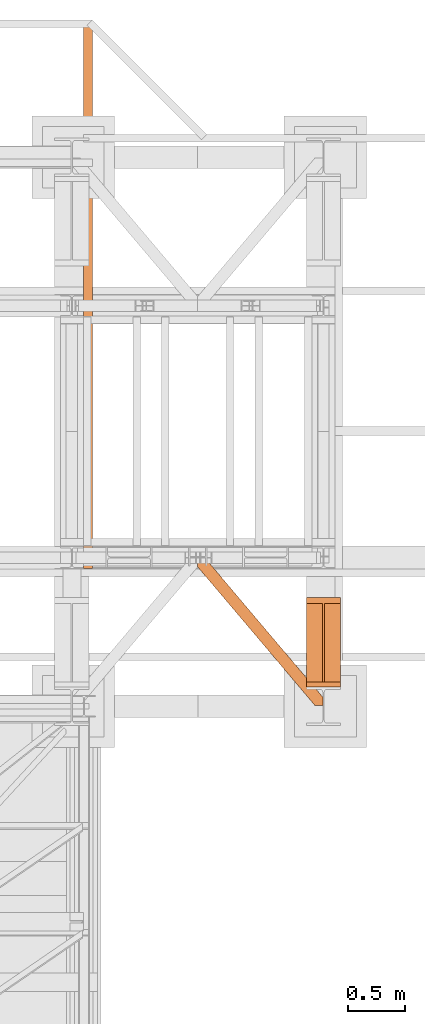
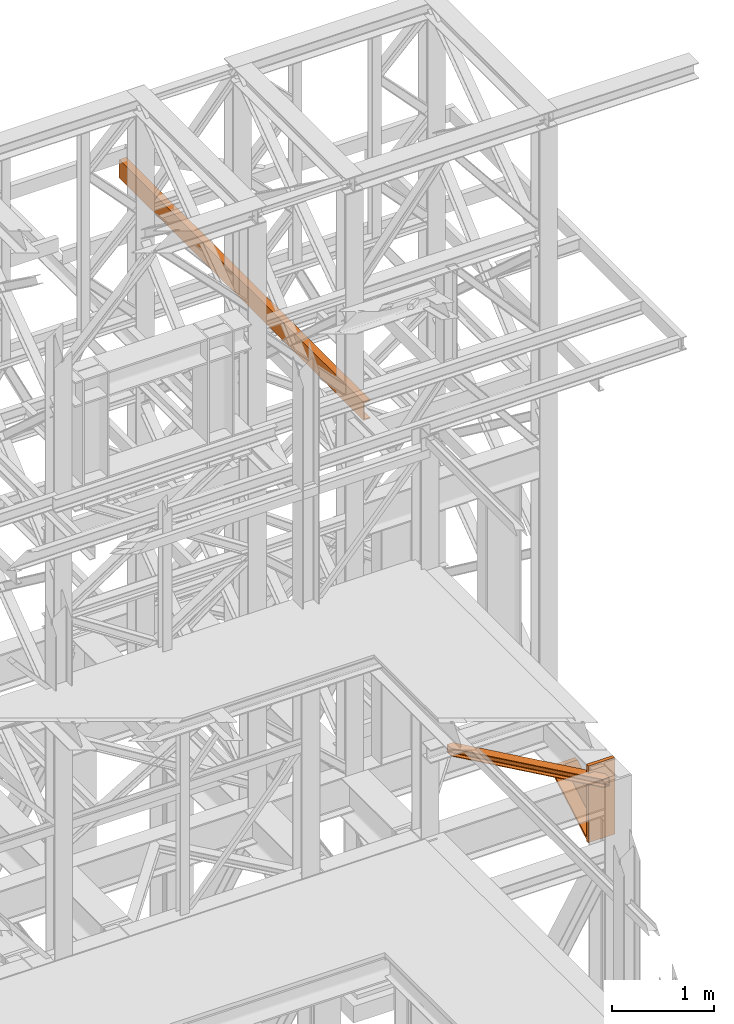
# One storey, part 175 of 208: 3 proxies.
"""IFC2X3 building model written with IfcOpenShell, lengths in millimetres."""

from ifc_helpers import new_model, entity, si_unit, converted_unit, frame, origin, origin_with_axes, place, context, subcontext, project, spatial, faceted_brep, element, save


model = new_model("IFC2X3")

# Units and contexts
model_context = context("Model", 3, precision=1e-05, world=origin())
plan_context = context("Plan", 3, precision=1e-05, world=origin())
body_context = subcontext(model_context, "Body", "Model", "MODEL_VIEW")
ifc_project = project(units=[si_unit("LENGTHUNIT", "METRE", prefix="MILLI"), converted_unit("PLANEANGLEUNIT", "DEGREE", entity("IfcPlaneAngleMeasure", 0.0174532925199433), si_unit("PLANEANGLEUNIT", "RADIAN"), dimensions=[0, 0, 0, 0, 0, 0, 0]), si_unit("AREAUNIT", "SQUARE_METRE"), si_unit("VOLUMEUNIT", "CUBIC_METRE")], contexts=[model_context, plan_context])

# Building, storey
building_placement = place(None, origin())
building = spatial("IfcBuilding", under=ifc_project, at=building_placement, CompositionType="COMPLEX")
storey_placement = place(building_placement, origin_with_axes())
storey = spatial("IfcBuildingStorey", under=building, at=storey_placement, Name="Geschoss", CompositionType="ELEMENT")

# Proxies
proxy_1_placement = place(storey_placement, frame((8643.254974489131, -17092.57439173937, 4367.230005364415), z_axis=(0.0, 0.0, 1.0), x_axis=(1.0, 0.0, 0.0)))
element("IfcBuildingElementProxy", 1, at=proxy_1_placement, inside=storey, context=body_context, shape_type="Brep", body=[
    faceted_brep([(0.01000000000021828, 40.0099999999984, 18.61000000000058), (300.0100000000002, 40.0099999999984, 18.61000000000058), (300.0100000000002, 779.8719999999976, 445.7700000000004), (0.01000000000021828, 779.8719999999976, 445.7700000000004), (0.01000000000021828, 779.8719999999976, 445.7700000000004), (300.0100000000002, 779.8719999999976, 445.7700000000004), (300.0100000000002, 729.8159999999989, 445.7710000000006), (157.5100000000002, 729.8159999999989, 445.7710000000006), (157.5100000000002, 40.0099999999984, 445.7700000000004), (142.5100000000002, 40.0099999999984, 445.7700000000004), (142.5100000000002, 729.8159999999989, 445.7710000000006), (0.01000000000021828, 729.8159999999971, 445.7710000000006), (0.01000000000021828, 729.8159999999971, 445.7710000000006), (142.5100000000002, 729.8159999999989, 445.7710000000006), (142.5100000000002, 40.0099999999984, 47.51000000000022), (0.01000000000021828, 40.0099999999984, 47.51000000000022), (157.5100000000002, 40.0099999999984, 47.51000000000022), (157.5100000000002, 729.8159999999989, 445.7710000000006), (300.0100000000002, 729.8159999999989, 445.7710000000006), (300.0100000000002, 40.0099999999984, 47.51000000000022), (0.01000000000021828, 40.0099999999984, 18.61000000000058), (0.01000000000021828, 779.8719999999976, 445.7700000000004), (0.01000000000021828, 729.8159999999971, 445.7710000000006), (0.01000000000021828, 40.0099999999984, 47.51000000000022), (0.01000000000021828, 40.0099999999984, 917.7700000000004), (0.01000000000021828, 0.00999999999839929, 917.7700000000004), (0.01000000000021828, 0.00999999999839929, 0.01000000000021828), (0.01000000000021828, 40.0099999999984, 0.01000000000021828), (300.0100000000002, 0.00999999999839929, 917.7700000000004), (300.0100000000002, 40.0099999999984, 917.7700000000004), (300.0100000000002, 40.0099999999984, 47.51000000000022), (300.0100000000002, 729.8159999999989, 445.7710000000006), (300.0100000000002, 779.8719999999976, 445.7700000000004), (300.0100000000002, 40.0099999999984, 18.61000000000058), (300.0100000000002, 40.0099999999984, 0.01000000000021828), (300.0100000000002, 0.00999999999839929, 0.01000000000021828), (300.0100000000002, 0.00999999999839929, 917.7700000000004), (0.01000000000021828, 0.00999999999839929, 917.7700000000004), (0.01000000000021828, 40.0099999999984, 917.7700000000004), (300.0100000000002, 40.0099999999984, 917.7700000000004), (300.0100000000002, 40.0099999999984, 917.7700000000004), (0.01000000000021828, 40.0099999999984, 917.7700000000004), (0.01000000000021828, 40.0099999999984, 47.51000000000022), (142.5100000000002, 40.0099999999984, 47.51000000000022), (142.5100000000002, 40.0099999999984, 445.7700000000004), (157.5100000000002, 40.0099999999984, 445.7700000000004), (157.5100000000002, 40.0099999999984, 47.51000000000022), (300.0100000000002, 40.0099999999984, 47.51000000000022), (300.0100000000002, 40.0099999999984, 18.61000000000058), (0.01000000000021828, 40.0099999999984, 18.61000000000058), (0.01000000000021828, 40.0099999999984, 0.01000000000021828), (300.0100000000002, 40.0099999999984, 0.01000000000021828), (300.0100000000002, 40.0099999999984, 0.01000000000021828), (0.01000000000021828, 40.0099999999984, 0.01000000000021828), (0.01000000000021828, 0.00999999999839929, 0.01000000000021828), (300.0100000000002, 0.00999999999839929, 0.01000000000021828), (300.0100000000002, 0.00999999999839929, 0.01000000000021828), (0.01000000000021828, 0.00999999999839929, 0.01000000000021828), (0.01000000000021828, 0.00999999999839929, 917.7700000000004), (300.0100000000002, 0.00999999999839929, 917.7700000000004), (142.5100000000002, 40.0099999999984, 47.51000000000022), (142.5100000000002, 729.8159999999989, 445.7710000000006), (142.5100000000002, 40.0099999999984, 445.7700000000004), (157.5100000000002, 40.0099999999984, 47.51000000000022), (157.5100000000002, 40.0099999999984, 445.7700000000004), (157.5100000000002, 729.8159999999989, 445.7710000000006)], [[[0, 1, 2, 3]], [[4, 5, 6, 7, 8, 9, 10, 11]], [[12, 13, 14, 15]], [[16, 17, 18, 19]], [[20, 21, 22, 23, 24, 25, 26, 27]], [[28, 29, 30, 31, 32, 33, 34, 35]], [[36, 37, 38, 39]], [[40, 41, 42, 43, 44, 45, 46, 47]], [[48, 49, 50, 51]], [[52, 53, 54, 55]], [[56, 57, 58, 59]], [[60, 61, 62]], [[63, 64, 65]]], orient=[[False], [False], [False], [False], [False], [False], [False], [False], [False], [False], [False], [False], [False]]),
])
proxy_2_placement = place(storey_placement, frame((7693.254968528679, -17257.87439359531, 5101.99001616488), z_axis=(0.0, 0.0, 1.0), x_axis=(1.0, 0.0, 0.0)))
element("IfcBuildingElementProxy", 2, at=proxy_2_placement, inside=storey, context=body_context, shape_type="Brep", body=[
    faceted_brep([(65.5076408449404, 1290.610003345228, 8.010001311303313), (65.5076408449404, 1290.610003345228, 0.01000000000112777), (1094.009999947834, 75.10721531453237, 0.01000000000112777), (1094.009999947834, 75.10721531453237, 8.010001311302403), (65.5076408449404, 1290.610003345228, 0.01000000000112777), (0.01000000000294676, 1290.610003345228, 0.01000000000112777), (0.01000000000294676, 1213.20370052848, 0.01000000000112777), (1026.558515831796, 0.00999999999839929, 0.01000000000021828), (1094.009999947834, 0.00999999999839929, 0.01000000000021828), (1094.009999947834, 75.10721531453237, 0.01000000000112777), (0.01000000000294676, 1213.20370052848, 0.01000000000112777), (0.01000000000203727, 1213.203700528482, 8.010001311303313), (1026.558515831796, 0.00999999999839929, 8.010001311303313), (1026.558515831796, 0.00999999999839929, 0.01000000000021828), (0.01000000000203727, 1213.203700528482, 8.010001311303313), (0.01000000000294676, 1268.162175066993, 8.010001311303313), (1073.061840441306, 0.00999999999839929, 8.010001311303313), (1026.558515831796, 0.00999999999839929, 8.010001311303313), (0.01000000000294676, 1268.162175066993, 8.010001311303313), (0.01000000000203727, 1277.776874373867, 9.253033826352294), (1081.197355239431, 0.00999999999839929, 9.253033826352294), (1073.061840441306, 0.00999999999839929, 8.010001311303313), (0.01000000000203727, 1277.776874373867, 9.253033826352294), (0.01000000000203727, 1284.815317712277, 13.79946006298178), (1087.152961141162, 0.00999999999839929, 13.79946006298178), (1081.197355239431, 0.00999999999839929, 9.253033826352294), (0.01000000000203727, 1284.815317712277, 13.79946006298178), (0.01000000000294676, 1286.739687988116, 20.01000141561144), (1088.781274451488, 0.00999999999839929, 20.01000141561144), (1087.152961141162, 0.00999999999839929, 13.79946006298178), (0.01000000000294676, 1286.739687988116, 20.01000141561144), (0.01000000000294676, 1286.739687988116, 76.01000128150099), (1088.781274451488, 0.00999999999839929, 76.01000128150099), (1088.781274451488, 0.00999999999839929, 20.01000141561144), (0.01000000000294676, 1286.739687988116, 76.01000128150099), (0.01000000000203727, 1284.815317712277, 82.2205407714855), (1087.152961141162, 0.00999999999839929, 82.2205407714855), (1088.781274451488, 0.00999999999839929, 76.01000128150099), (0.01000000000203727, 1284.815317712277, 82.2205407714855), (0.01000000000203727, 1277.776874373867, 86.76696700811499), (1081.197355239431, 0.00999999999839929, 86.76696700811499), (1087.152961141162, 0.00999999999839929, 82.2205407714855), (0.01000000000203727, 1277.776874373867, 86.76696700811499), (0.01000000000203727, 1268.162175066993, 88.00999952316397), (1073.061840441304, 0.00999999999839929, 88.00999952316397), (1081.197355239431, 0.00999999999839929, 86.76696700811499), (0.01000000000203727, 1268.162175066993, 88.00999952316397), (0.01000000000294676, 1213.20370052848, 88.00999952316397), (1026.558515831796, 0.00999999999839929, 88.00999952316397), (1073.061840441304, 0.00999999999839929, 88.00999952316397), (0.01000000000294676, 1213.20370052848, 88.00999952316397), (0.01000000000021828, 1213.203700528484, 96.01000083446615), (1026.558515831796, 0.00999999999839929, 96.01000083446615), (1026.558515831796, 0.00999999999839929, 88.00999952316397), (0.01000000000021828, 1213.203700528484, 96.01000083446615), (0.01000000000112777, 1290.610003345228, 96.01000083446615), (65.50764084493858, 1290.610003345228, 96.01000083446615), (1094.009999947834, 75.10721531453237, 96.01000083446615), (1094.009999947834, 0.00999999999839929, 96.01000083446615), (1026.558515831796, 0.00999999999839929, 96.01000083446615), (65.50764084493858, 1290.610003345228, 96.01000083446615), (65.50764084493858, 1290.610003345228, 88.00999952316397), (1094.009999947834, 75.10721531453237, 88.00999952316397), (1094.009999947834, 75.10721531453237, 96.01000083446615), (65.50764084493858, 1290.610003345228, 88.00999952316397), (19.00431623542772, 1290.610003345228, 88.00999952316397), (1094.009999947834, 20.14874077602144, 88.00999952316397), (1094.009999947834, 75.10721531453237, 88.00999952316397), (19.00431623542772, 1290.610003345228, 88.00999952316397), (10.86880143730195, 1290.610003345228, 86.76696700811499), (1094.009999947834, 10.53404146914545, 86.76696700811499), (1094.009999947834, 20.14874077602144, 88.00999952316397), (10.86880143730195, 1290.610003345228, 86.76696700811499), (4.913195535573323, 1290.610003345228, 82.2205407714855), (1094.009999947834, 3.495598130735743, 82.2205407714855), (1094.009999947834, 10.53404146914545, 86.76696700811499), (4.913195535573323, 1290.610003345228, 82.2205407714855), (3.284882225245383, 1290.610003345228, 76.01000128150099), (1094.009999947834, 1.571227854896279, 76.01000128150099), (1094.009999947834, 3.495598130735743, 82.2205407714855), (3.284882225245383, 1290.610003345228, 76.01000128150099), (3.284882225246292, 1290.610003345228, 20.01000141561144), (1094.009999947834, 1.571227854896279, 20.01000141561144), (1094.009999947834, 1.571227854896279, 76.01000128150099), (3.284882225246292, 1290.610003345228, 20.01000141561144), (4.913195535572413, 1290.610003345228, 13.79946006298178), (1094.009999947834, 3.495598130735743, 13.79946006298178), (1094.009999947834, 1.571227854896279, 20.01000141561144), (4.913195535572413, 1290.610003345228, 13.79946006298178), (10.86880143730377, 1290.610003345228, 9.253033826352294), (1094.009999947834, 10.53404146914545, 9.253033826352294), (1094.009999947834, 3.495598130735743, 13.79946006298178), (10.86880143730377, 1290.610003345228, 9.253033826352294), (19.00431623542954, 1290.610003345228, 8.010001311303313), (1094.009999947834, 20.14874077602144, 8.010001311303313), (1094.009999947834, 10.53404146914545, 9.253033826352294), (19.00431623542954, 1290.610003345228, 8.010001311303313), (65.5076408449404, 1290.610003345228, 8.010001311303313), (1094.009999947834, 75.10721531453237, 8.010001311302403), (1094.009999947834, 20.14874077602144, 8.010001311303313), (0.01000000000294676, 1213.20370052848, 0.01000000000112777), (0.01000000000294676, 1290.610003345228, 0.01000000000112777), (0.01000000000112777, 1290.610003345228, 96.01000083446615), (0.01000000000021828, 1213.203700528484, 96.01000083446615), (0.01000000000294676, 1213.20370052848, 88.00999952316397), (0.01000000000203727, 1268.162175066993, 88.00999952316397), (0.01000000000203727, 1277.776874373867, 86.76696700811499), (0.01000000000203727, 1284.815317712277, 82.2205407714855), (0.01000000000294676, 1286.739687988116, 76.01000128150099), (0.01000000000294676, 1286.739687988116, 20.01000141561144), (0.01000000000203727, 1284.815317712277, 13.79946006298178), (0.01000000000203727, 1277.776874373867, 9.253033826352294), (0.01000000000294676, 1268.162175066993, 8.010001311303313), (0.01000000000203727, 1213.203700528482, 8.010001311303313), (0.01000000000112777, 1290.610003345228, 96.01000083446615), (0.01000000000294676, 1290.610003345228, 0.01000000000112777), (65.5076408449404, 1290.610003345228, 0.01000000000112777), (65.5076408449404, 1290.610003345228, 8.010001311303313), (19.00431623542954, 1290.610003345228, 8.010001311303313), (10.86880143730377, 1290.610003345228, 9.253033826352294), (4.913195535572413, 1290.610003345228, 13.79946006298178), (3.284882225246292, 1290.610003345228, 20.01000141561144), (3.284882225245383, 1290.610003345228, 76.01000128150099), (4.913195535573323, 1290.610003345228, 82.2205407714855), (10.86880143730195, 1290.610003345228, 86.76696700811499), (19.00431623542772, 1290.610003345228, 88.00999952316397), (65.50764084493858, 1290.610003345228, 88.00999952316397), (65.50764084493858, 1290.610003345228, 96.01000083446615), (1094.009999947834, 75.10721531453237, 8.010001311302403), (1094.009999947834, 75.10721531453237, 0.01000000000112777), (1094.009999947834, 0.00999999999839929, 0.01000000000021828), (1094.009999947834, 0.00999999999839929, 96.01000083446615), (1094.009999947834, 75.10721531453237, 96.01000083446615), (1094.009999947834, 75.10721531453237, 88.00999952316397), (1094.009999947834, 20.14874077602144, 88.00999952316397), (1094.009999947834, 10.53404146914545, 86.76696700811499), (1094.009999947834, 3.495598130735743, 82.2205407714855), (1094.009999947834, 1.571227854896279, 76.01000128150099), (1094.009999947834, 1.571227854896279, 20.01000141561144), (1094.009999947834, 3.495598130735743, 13.79946006298178), (1094.009999947834, 10.53404146914545, 9.253033826352294), (1094.009999947834, 20.14874077602144, 8.010001311303313), (1094.009999947834, 0.00999999999839929, 0.01000000000021828), (1026.558515831796, 0.00999999999839929, 0.01000000000021828), (1026.558515831796, 0.00999999999839929, 8.010001311303313), (1073.061840441306, 0.00999999999839929, 8.010001311303313), (1081.197355239431, 0.00999999999839929, 9.253033826352294), (1087.152961141162, 0.00999999999839929, 13.79946006298178), (1088.781274451488, 0.00999999999839929, 20.01000141561144), (1088.781274451488, 0.00999999999839929, 76.01000128150099), (1087.152961141162, 0.00999999999839929, 82.2205407714855), (1081.197355239431, 0.00999999999839929, 86.76696700811499), (1073.061840441304, 0.00999999999839929, 88.00999952316397), (1026.558515831796, 0.00999999999839929, 88.00999952316397), (1026.558515831796, 0.00999999999839929, 96.01000083446615), (1094.009999947834, 0.00999999999839929, 96.01000083446615)], [[[0, 1, 2, 3]], [[4, 5, 6, 7, 8, 9]], [[10, 11, 12, 13]], [[14, 15, 16, 17]], [[18, 19, 20, 21]], [[22, 23, 24, 25]], [[26, 27, 28, 29]], [[30, 31, 32, 33]], [[34, 35, 36, 37]], [[38, 39, 40, 41]], [[42, 43, 44, 45]], [[46, 47, 48, 49]], [[50, 51, 52, 53]], [[54, 55, 56, 57, 58, 59]], [[60, 61, 62, 63]], [[64, 65, 66, 67]], [[68, 69, 70, 71]], [[72, 73, 74, 75]], [[76, 77, 78, 79]], [[80, 81, 82, 83]], [[84, 85, 86, 87]], [[88, 89, 90, 91]], [[92, 93, 94, 95]], [[96, 97, 98, 99]], [[100, 101, 102, 103, 104, 105, 106, 107, 108, 109, 110, 111, 112, 113]], [[114, 115, 116, 117, 118, 119, 120, 121, 122, 123, 124, 125, 126, 127]], [[128, 129, 130, 131, 132, 133, 134, 135, 136, 137, 138, 139, 140, 141]], [[142, 143, 144, 145, 146, 147, 148, 149, 150, 151, 152, 153, 154, 155]]], orient=[[False], [False], [False], [False], [False], [False], [False], [False], [False], [False], [False], [False], [False], [False], [False], [False], [False], [False], [False], [False], [False], [False], [False], [False], [False], [False], [False], [False]]),
])
proxy_3_placement = place(storey_placement, frame((6693.254970018783, -16057.57439657638, 9479.99), z_axis=(0.0, 0.0, 1.0), x_axis=(1.0, 0.0, 0.0)))
element("IfcBuildingElementProxy", 3, at=proxy_3_placement, inside=storey, context=body_context, shape_type="Brep", body=[
    faceted_brep([(80.00999999999931, 4795.01000774861, 0.01000000000021828), (80.01000000000113, 0.01000000000021828, 0.01000000000021828), (80.01000000000113, 0.01000000000021828, 3.66923317392866), (80.00999999999931, 4795.01000774861, 3.66923317392866), (80.00999999999931, 4795.01000774861, 3.66923317392866), (80.01000000000113, 0.01000000000021828, 3.66923317392866), (79.72312949970456, 0.01000000000021828, 5.578886891475122), (79.72312949970274, 4795.01000774861, 5.578886891475122), (79.72312949970274, 4795.01000774861, 5.578886891475122), (79.72312949970456, 0.01000000000021828, 5.578886891475122), (78.8879017923764, 0.01000000000021828, 7.319995251345972), (78.88790179237458, 4795.01000774861, 7.319995251345972), (78.88790179237458, 4795.01000774861, 7.319995251345972), (78.8879017923764, 0.01000000000021828, 7.319995251345972), (77.57799739091843, 0.01000000000021828, 8.73887701366948), (77.57799739091661, 4795.01000774861, 8.73887701366948), (77.57799739091661, 4795.01000774861, 8.73887701366948), (77.57799739091843, 0.01000000000021828, 8.73887701366948), (75.90903939539203, 0.01000000000021828, 9.710289826567532), (75.90903939539021, 4795.01000774861, 9.710289826567532), (75.90903939539021, 4795.01000774861, 9.710289826567532), (75.90903939539203, 0.01000000000021828, 9.710289826567532), (74.02834394483943, 0.01000000000021828, 10.1485324844125), (74.02834394483762, 4795.01000774861, 10.1485324844125), (74.02834394483762, 4795.01000774861, 10.1485324844125), (74.02834394483943, 0.01000000000021828, 10.1485324844125), (20.5131847214634, 0.01000000000021828, 14.4297452222836), (20.5131847214634, 4795.01000774861, 14.4297452222836), (20.5131847214634, 4795.01000774861, 14.4297452222836), (20.5131847214634, 0.01000000000021828, 14.4297452222836), (16.89646270117191, 0.01000000000021828, 15.27251956429427), (16.89646270117009, 4795.01000774861, 15.27251956429427), (16.89646270117009, 4795.01000774861, 15.27251956429427), (16.89646270117191, 0.01000000000021828, 15.27251956429427), (13.68692809438835, 0.01000000000021828, 17.14062112755892), (13.68692809438835, 4795.01000774861, 17.14062112755892), (13.68692809438835, 4795.01000774861, 17.14062112755892), (13.68692809438835, 0.01000000000021828, 17.14062112755892), (11.16788116850876, 0.01000000000021828, 19.86923990125979), (11.16788116850876, 4795.01000774861, 19.86923990125979), (11.16788116850876, 4795.01000774861, 19.86923990125979), (11.16788116850876, 0.01000000000021828, 19.86923990125979), (9.56167403903055, 0.01000000000021828, 23.21752520870177), (9.56167403903055, 4795.01000774861, 23.21752520870177), (9.56167403903055, 4795.01000774861, 23.21752520870177), (9.56167403903055, 0.01000000000021828, 23.21752520870177), (9.010000000000218, 0.01000000000021828, 26.88993620398469), (9.010000000000218, 4795.01000774861, 26.88993620398469), (9.010000000000218, 4795.01000774861, 26.88993620398469), (9.010000000000218, 0.01000000000021828, 26.88993620398469), (9.010000000000218, 0.01000000000021828, 193.1300637960158), (9.010000000000218, 4795.01000774861, 193.1300637960158), (9.010000000000218, 4795.01000774861, 193.1300637960158), (9.010000000000218, 0.01000000000021828, 193.1300637960158), (9.56167403903055, 0.01000000000021828, 196.8024747913005), (9.56167403903055, 4795.01000774861, 196.8024747913005), (9.56167403903055, 4795.01000774861, 196.8024747913005), (9.56167403903055, 0.01000000000021828, 196.8024747913005), (11.16788116850876, 0.01000000000021828, 200.1507600987407), (11.16788116850876, 4795.01000774861, 200.1507600987407), (11.16788116850876, 4795.01000774861, 200.1507600987407), (11.16788116850876, 0.01000000000021828, 200.1507600987407), (13.68692809439017, 0.01000000000021828, 202.8793788724415), (13.68692809438835, 4795.01000774861, 202.8793788724415), (13.68692809438835, 4795.01000774861, 202.8793788724415), (13.68692809439017, 0.01000000000021828, 202.8793788724415), (16.89646270117191, 0.01000000000021828, 204.7474804357062), (16.89646270117009, 4795.01000774861, 204.7474804357062), (16.89646270117009, 4795.01000774861, 204.7474804357062), (16.89646270117191, 0.01000000000021828, 204.7474804357062), (20.51318472146522, 0.01000000000021828, 205.5902547777168), (20.5131847214634, 4795.01000774861, 205.5902547777168), (20.5131847214634, 4795.01000774861, 205.5902547777168), (20.51318472146522, 0.01000000000021828, 205.5902547777168), (74.02834394483943, 0.01000000000021828, 209.8714675155879), (74.02834394483762, 4795.01000774861, 209.8714675155879), (74.02834394483762, 4795.01000774861, 209.8714675155879), (74.02834394483943, 0.01000000000021828, 209.8714675155879), (75.90903939539203, 0.01000000000021828, 210.3097101734329), (75.90903939539021, 4795.01000774861, 210.3097101734329), (75.90903939539021, 4795.01000774861, 210.3097101734329), (75.90903939539203, 0.01000000000021828, 210.3097101734329), (77.57799739091843, 0.01000000000021828, 211.281122986331), (77.57799739091661, 4795.01000774861, 211.281122986331), (77.57799739091661, 4795.01000774861, 211.281122986331), (77.57799739091843, 0.01000000000021828, 211.281122986331), (78.8879017923764, 0.01000000000021828, 212.7000047486563), (78.88790179237458, 4795.01000774861, 212.7000047486563), (78.88790179237458, 4795.01000774861, 212.7000047486563), (78.8879017923764, 0.01000000000021828, 212.7000047486563), (79.72312949970456, 0.01000000000021828, 214.4411131085253), (79.72312949970274, 4795.01000774861, 214.4411131085253), (79.72312949970274, 4795.01000774861, 214.4411131085253), (79.72312949970456, 0.01000000000021828, 214.4411131085253), (80.01000000000113, 0.01000000000021828, 216.3507668260718), (80.00999999999931, 4795.01000774861, 216.3507668260718), (80.00999999999931, 4795.01000774861, 216.3507668260718), (80.01000000000113, 0.01000000000021828, 216.3507668260718), (80.01000000000113, 0.01000000000021828, 220.0100000000002), (80.00999999999931, 4795.01000774861, 220.0100000000002), (80.00999999999931, 4795.01000774861, 220.0100000000002), (80.01000000000113, 0.01000000000021828, 220.0100000000002), (0.01000000000021828, 0.01000000000021828, 220.0100000000002), (0.01000000000021828, 4795.01000774861, 220.0100000000002), (0.01000000000021828, 4795.01000774861, 220.0100000000002), (0.01000000000021828, 0.01000000000021828, 220.0100000000002), (0.01000000000021828, 0.01000000000021828, 0.01000000000021828), (0.01000000000021828, 4795.01000774861, 0.01000000000021828), (0.01000000000021828, 4795.01000774861, 0.01000000000021828), (0.01000000000021828, 0.01000000000021828, 0.01000000000021828), (80.01000000000113, 0.01000000000021828, 0.01000000000021828), (80.00999999999931, 4795.01000774861, 0.01000000000021828), (80.00999999999931, 4795.01000774861, 0.01000000000021828), (80.00999999999931, 4795.01000774861, 3.66923317392866), (79.72312949970274, 4795.01000774861, 5.578886891475122), (78.88790179237458, 4795.01000774861, 7.319995251345972), (77.57799739091661, 4795.01000774861, 8.73887701366948), (75.90903939539021, 4795.01000774861, 9.710289826567532), (74.02834394483762, 4795.01000774861, 10.1485324844125), (20.5131847214634, 4795.01000774861, 14.4297452222836), (16.89646270117009, 4795.01000774861, 15.27251956429427), (13.68692809438835, 4795.01000774861, 17.14062112755892), (11.16788116850876, 4795.01000774861, 19.86923990125979), (9.56167403903055, 4795.01000774861, 23.21752520870177), (9.010000000000218, 4795.01000774861, 26.88993620398469), (9.010000000000218, 4795.01000774861, 193.1300637960158), (9.56167403903055, 4795.01000774861, 196.8024747913005), (11.16788116850876, 4795.01000774861, 200.1507600987407), (13.68692809438835, 4795.01000774861, 202.8793788724415), (16.89646270117009, 4795.01000774861, 204.7474804357062), (20.5131847214634, 4795.01000774861, 205.5902547777168), (74.02834394483762, 4795.01000774861, 209.8714675155879), (75.90903939539021, 4795.01000774861, 210.3097101734329), (77.57799739091661, 4795.01000774861, 211.281122986331), (78.88790179237458, 4795.01000774861, 212.7000047486563), (79.72312949970274, 4795.01000774861, 214.4411131085253), (80.00999999999931, 4795.01000774861, 216.3507668260718), (80.00999999999931, 4795.01000774861, 220.0100000000002), (0.01000000000021828, 4795.01000774861, 220.0100000000002), (0.01000000000021828, 4795.01000774861, 0.01000000000021828), (80.01000000000113, 0.01000000000021828, 0.01000000000021828), (0.01000000000021828, 0.01000000000021828, 0.01000000000021828), (0.01000000000021828, 0.01000000000021828, 220.0100000000002), (80.01000000000113, 0.01000000000021828, 220.0100000000002), (80.01000000000113, 0.01000000000021828, 216.3507668260718), (79.72312949970456, 0.01000000000021828, 214.4411131085253), (78.8879017923764, 0.01000000000021828, 212.7000047486563), (77.57799739091843, 0.01000000000021828, 211.281122986331), (75.90903939539203, 0.01000000000021828, 210.3097101734329), (74.02834394483943, 0.01000000000021828, 209.8714675155879), (20.51318472146522, 0.01000000000021828, 205.5902547777168), (16.89646270117191, 0.01000000000021828, 204.7474804357062), (13.68692809439017, 0.01000000000021828, 202.8793788724415), (11.16788116850876, 0.01000000000021828, 200.1507600987407), (9.56167403903055, 0.01000000000021828, 196.8024747913005), (9.010000000000218, 0.01000000000021828, 193.1300637960158), (9.010000000000218, 0.01000000000021828, 26.88993620398469), (9.56167403903055, 0.01000000000021828, 23.21752520870177), (11.16788116850876, 0.01000000000021828, 19.86923990125979), (13.68692809438835, 0.01000000000021828, 17.14062112755892), (16.89646270117191, 0.01000000000021828, 15.27251956429427), (20.5131847214634, 0.01000000000021828, 14.4297452222836), (74.02834394483943, 0.01000000000021828, 10.1485324844125), (75.90903939539203, 0.01000000000021828, 9.710289826567532), (77.57799739091843, 0.01000000000021828, 8.73887701366948), (78.8879017923764, 0.01000000000021828, 7.319995251345972), (79.72312949970456, 0.01000000000021828, 5.578886891475122), (80.01000000000113, 0.01000000000021828, 3.66923317392866)], [[[0, 1, 2, 3]], [[4, 5, 6, 7]], [[8, 9, 10, 11]], [[12, 13, 14, 15]], [[16, 17, 18, 19]], [[20, 21, 22, 23]], [[24, 25, 26, 27]], [[28, 29, 30, 31]], [[32, 33, 34, 35]], [[36, 37, 38, 39]], [[40, 41, 42, 43]], [[44, 45, 46, 47]], [[48, 49, 50, 51]], [[52, 53, 54, 55]], [[56, 57, 58, 59]], [[60, 61, 62, 63]], [[64, 65, 66, 67]], [[68, 69, 70, 71]], [[72, 73, 74, 75]], [[76, 77, 78, 79]], [[80, 81, 82, 83]], [[84, 85, 86, 87]], [[88, 89, 90, 91]], [[92, 93, 94, 95]], [[96, 97, 98, 99]], [[100, 101, 102, 103]], [[104, 105, 106, 107]], [[108, 109, 110, 111]], [[112, 113, 114, 115, 116, 117, 118, 119, 120, 121, 122, 123, 124, 125, 126, 127, 128, 129, 130, 131, 132, 133, 134, 135, 136, 137, 138, 139]], [[140, 141, 142, 143, 144, 145, 146, 147, 148, 149, 150, 151, 152, 153, 154, 155, 156, 157, 158, 159, 160, 161, 162, 163, 164, 165, 166, 167]]], orient=[[False], [False], [False], [False], [False], [False], [False], [False], [False], [False], [False], [False], [False], [False], [False], [False], [False], [False], [False], [False], [False], [False], [False], [False], [False], [False], [False], [False], [False], [False]]),
])

save(model, "model.ifc")
